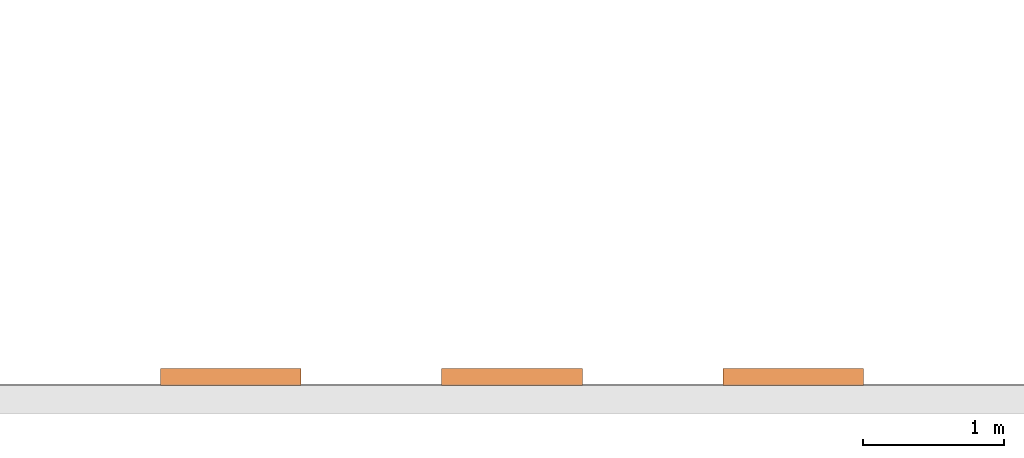
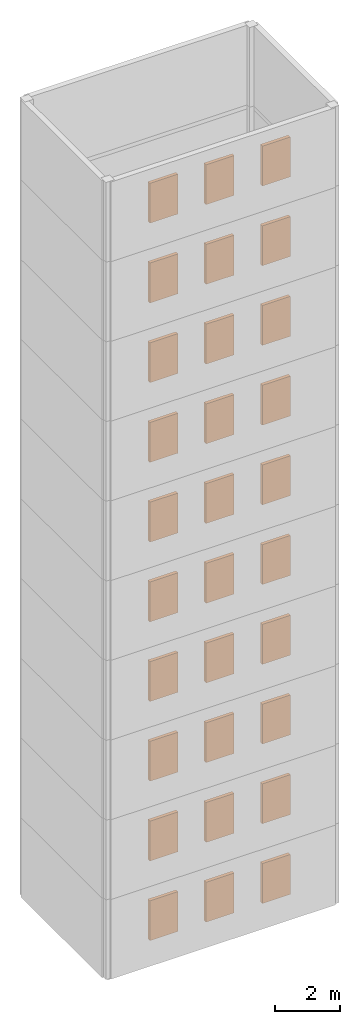
# Not in any storey, part 3 of 3: 30 proxies.
"""IFC4 model written with IfcOpenShell, lengths in metres."""

from ifc_helpers import new_model, si_unit, origin_with_axes, place, context, project, faceted_brep, element, save


model = new_model("IFC4")

# Units and contexts
model_context = context("Model", 3, precision=1e-05, world=origin_with_axes())
ifc_project = project(units=[si_unit("LENGTHUNIT", "METRE"), si_unit("AREAUNIT", "SQUARE_METRE"), si_unit("VOLUMEUNIT", "CUBIC_METRE")], contexts=[model_context])

# Proxies
proxy_1_placement = place(None, origin_with_axes())
element("IfcBuildingElementProxy", 1, at=proxy_1_placement, context=model_context, shape_type="SurfaceModel", body=[
    faceted_brep([(1.5, 0.0, 0.8), (1.5, 0.0, 2.3), (2.5, 0.0, 2.3), (2.5, 0.0, 0.8), (1.5, 0.12, 0.8), (2.5, 0.12, 0.8), (2.5, 0.12, 2.3), (1.5, 0.12, 2.3)], [[[0, 1, 2, 3]], [[4, 5, 6, 7]], [[0, 3, 5, 4]], [[1, 7, 6, 2]], [[0, 4, 7, 1]], [[3, 2, 6, 5]]]),
])
proxy_2_placement = place(None, origin_with_axes())
element("IfcBuildingElementProxy", 2, at=proxy_2_placement, context=model_context, shape_type="SurfaceModel", body=[
    faceted_brep([(3.5, 0.0, 0.8), (3.5, 0.0, 2.3), (4.5, 0.0, 2.3), (4.5, 0.0, 0.8), (3.5, 0.12, 0.8), (4.5, 0.12, 0.8), (4.5, 0.12, 2.3), (3.5, 0.12, 2.3)], [[[0, 1, 2, 3]], [[4, 5, 6, 7]], [[0, 3, 5, 4]], [[1, 7, 6, 2]], [[0, 4, 7, 1]], [[3, 2, 6, 5]]]),
])
proxy_3_placement = place(None, origin_with_axes())
element("IfcBuildingElementProxy", 3, at=proxy_3_placement, context=model_context, shape_type="SurfaceModel", body=[
    faceted_brep([(5.5, 0.0, 0.8), (5.5, 0.0, 2.3), (6.5, 0.0, 2.3), (6.5, 0.0, 0.8), (5.5, 0.12, 0.8), (6.5, 0.12, 0.8), (6.5, 0.12, 2.3), (5.5, 0.12, 2.3)], [[[0, 1, 2, 3]], [[4, 5, 6, 7]], [[0, 3, 5, 4]], [[1, 7, 6, 2]], [[0, 4, 7, 1]], [[3, 2, 6, 5]]]),
])
proxy_4_placement = place(None, origin_with_axes())
element("IfcBuildingElementProxy", 4, at=proxy_4_placement, context=model_context, shape_type="SurfaceModel", body=[
    faceted_brep([(1.5, 0.0, 3.8), (1.5, 0.0, 5.3), (2.5, 0.0, 5.3), (2.5, 0.0, 3.8), (1.5, 0.12, 3.8), (2.5, 0.12, 3.8), (2.5, 0.12, 5.3), (1.5, 0.12, 5.3)], [[[0, 1, 2, 3]], [[4, 5, 6, 7]], [[0, 3, 5, 4]], [[1, 7, 6, 2]], [[0, 4, 7, 1]], [[3, 2, 6, 5]]]),
])
proxy_5_placement = place(None, origin_with_axes())
element("IfcBuildingElementProxy", 5, at=proxy_5_placement, context=model_context, shape_type="SurfaceModel", body=[
    faceted_brep([(3.5, 0.0, 3.8), (3.5, 0.0, 5.3), (4.5, 0.0, 5.3), (4.5, 0.0, 3.8), (3.5, 0.12, 3.8), (4.5, 0.12, 3.8), (4.5, 0.12, 5.3), (3.5, 0.12, 5.3)], [[[0, 1, 2, 3]], [[4, 5, 6, 7]], [[0, 3, 5, 4]], [[1, 7, 6, 2]], [[0, 4, 7, 1]], [[3, 2, 6, 5]]]),
])
proxy_6_placement = place(None, origin_with_axes())
element("IfcBuildingElementProxy", 6, at=proxy_6_placement, context=model_context, shape_type="SurfaceModel", body=[
    faceted_brep([(5.5, 0.0, 3.8), (5.5, 0.0, 5.3), (6.5, 0.0, 5.3), (6.5, 0.0, 3.8), (5.5, 0.12, 3.8), (6.5, 0.12, 3.8), (6.5, 0.12, 5.3), (5.5, 0.12, 5.3)], [[[0, 1, 2, 3]], [[4, 5, 6, 7]], [[0, 3, 5, 4]], [[1, 7, 6, 2]], [[0, 4, 7, 1]], [[3, 2, 6, 5]]]),
])
proxy_7_placement = place(None, origin_with_axes())
element("IfcBuildingElementProxy", 7, at=proxy_7_placement, context=model_context, shape_type="SurfaceModel", body=[
    faceted_brep([(1.5, 0.0, 6.8), (1.5, 0.0, 8.3), (2.5, 0.0, 8.3), (2.5, 0.0, 6.8), (1.5, 0.12, 6.8), (2.5, 0.12, 6.8), (2.5, 0.12, 8.3), (1.5, 0.12, 8.3)], [[[0, 1, 2, 3]], [[4, 5, 6, 7]], [[0, 3, 5, 4]], [[1, 7, 6, 2]], [[0, 4, 7, 1]], [[3, 2, 6, 5]]]),
])
proxy_8_placement = place(None, origin_with_axes())
element("IfcBuildingElementProxy", 8, at=proxy_8_placement, context=model_context, shape_type="SurfaceModel", body=[
    faceted_brep([(3.5, 0.0, 6.8), (3.5, 0.0, 8.3), (4.5, 0.0, 8.3), (4.5, 0.0, 6.8), (3.5, 0.12, 6.8), (4.5, 0.12, 6.8), (4.5, 0.12, 8.3), (3.5, 0.12, 8.3)], [[[0, 1, 2, 3]], [[4, 5, 6, 7]], [[0, 3, 5, 4]], [[1, 7, 6, 2]], [[0, 4, 7, 1]], [[3, 2, 6, 5]]]),
])
proxy_9_placement = place(None, origin_with_axes())
element("IfcBuildingElementProxy", 9, at=proxy_9_placement, context=model_context, shape_type="SurfaceModel", body=[
    faceted_brep([(5.5, 0.0, 6.8), (5.5, 0.0, 8.3), (6.5, 0.0, 8.3), (6.5, 0.0, 6.8), (5.5, 0.12, 6.8), (6.5, 0.12, 6.8), (6.5, 0.12, 8.3), (5.5, 0.12, 8.3)], [[[0, 1, 2, 3]], [[4, 5, 6, 7]], [[0, 3, 5, 4]], [[1, 7, 6, 2]], [[0, 4, 7, 1]], [[3, 2, 6, 5]]]),
])
proxy_10_placement = place(None, origin_with_axes())
element("IfcBuildingElementProxy", 10, at=proxy_10_placement, context=model_context, shape_type="SurfaceModel", body=[
    faceted_brep([(1.5, 0.0, 9.8), (1.5, 0.0, 11.3), (2.5, 0.0, 11.3), (2.5, 0.0, 9.8), (1.5, 0.12, 9.8), (2.5, 0.12, 9.8), (2.5, 0.12, 11.3), (1.5, 0.12, 11.3)], [[[0, 1, 2, 3]], [[4, 5, 6, 7]], [[0, 3, 5, 4]], [[1, 7, 6, 2]], [[0, 4, 7, 1]], [[3, 2, 6, 5]]]),
])
proxy_11_placement = place(None, origin_with_axes())
element("IfcBuildingElementProxy", 11, at=proxy_11_placement, context=model_context, shape_type="SurfaceModel", body=[
    faceted_brep([(3.5, 0.0, 9.8), (3.5, 0.0, 11.3), (4.5, 0.0, 11.3), (4.5, 0.0, 9.8), (3.5, 0.12, 9.8), (4.5, 0.12, 9.8), (4.5, 0.12, 11.3), (3.5, 0.12, 11.3)], [[[0, 1, 2, 3]], [[4, 5, 6, 7]], [[0, 3, 5, 4]], [[1, 7, 6, 2]], [[0, 4, 7, 1]], [[3, 2, 6, 5]]]),
])
proxy_12_placement = place(None, origin_with_axes())
element("IfcBuildingElementProxy", 12, at=proxy_12_placement, context=model_context, shape_type="SurfaceModel", body=[
    faceted_brep([(5.5, 0.0, 9.8), (5.5, 0.0, 11.3), (6.5, 0.0, 11.3), (6.5, 0.0, 9.8), (5.5, 0.12, 9.8), (6.5, 0.12, 9.8), (6.5, 0.12, 11.3), (5.5, 0.12, 11.3)], [[[0, 1, 2, 3]], [[4, 5, 6, 7]], [[0, 3, 5, 4]], [[1, 7, 6, 2]], [[0, 4, 7, 1]], [[3, 2, 6, 5]]]),
])
proxy_13_placement = place(None, origin_with_axes())
element("IfcBuildingElementProxy", 13, at=proxy_13_placement, context=model_context, shape_type="SurfaceModel", body=[
    faceted_brep([(1.5, 0.0, 12.8), (1.5, 0.0, 14.3), (2.5, 0.0, 14.3), (2.5, 0.0, 12.8), (1.5, 0.12, 12.8), (2.5, 0.12, 12.8), (2.5, 0.12, 14.3), (1.5, 0.12, 14.3)], [[[0, 1, 2, 3]], [[4, 5, 6, 7]], [[0, 3, 5, 4]], [[1, 7, 6, 2]], [[0, 4, 7, 1]], [[3, 2, 6, 5]]]),
])
proxy_14_placement = place(None, origin_with_axes())
element("IfcBuildingElementProxy", 14, at=proxy_14_placement, context=model_context, shape_type="SurfaceModel", body=[
    faceted_brep([(3.5, 0.0, 12.8), (3.5, 0.0, 14.3), (4.5, 0.0, 14.3), (4.5, 0.0, 12.8), (3.5, 0.12, 12.8), (4.5, 0.12, 12.8), (4.5, 0.12, 14.3), (3.5, 0.12, 14.3)], [[[0, 1, 2, 3]], [[4, 5, 6, 7]], [[0, 3, 5, 4]], [[1, 7, 6, 2]], [[0, 4, 7, 1]], [[3, 2, 6, 5]]]),
])
proxy_15_placement = place(None, origin_with_axes())
element("IfcBuildingElementProxy", 15, at=proxy_15_placement, context=model_context, shape_type="SurfaceModel", body=[
    faceted_brep([(5.5, 0.0, 12.8), (5.5, 0.0, 14.3), (6.5, 0.0, 14.3), (6.5, 0.0, 12.8), (5.5, 0.12, 12.8), (6.5, 0.12, 12.8), (6.5, 0.12, 14.3), (5.5, 0.12, 14.3)], [[[0, 1, 2, 3]], [[4, 5, 6, 7]], [[0, 3, 5, 4]], [[1, 7, 6, 2]], [[0, 4, 7, 1]], [[3, 2, 6, 5]]]),
])
proxy_16_placement = place(None, origin_with_axes())
element("IfcBuildingElementProxy", 16, at=proxy_16_placement, context=model_context, shape_type="SurfaceModel", body=[
    faceted_brep([(1.5, 0.0, 15.8), (1.5, 0.0, 17.3), (2.5, 0.0, 17.3), (2.5, 0.0, 15.8), (1.5, 0.12, 15.8), (2.5, 0.12, 15.8), (2.5, 0.12, 17.3), (1.5, 0.12, 17.3)], [[[0, 1, 2, 3]], [[4, 5, 6, 7]], [[0, 3, 5, 4]], [[1, 7, 6, 2]], [[0, 4, 7, 1]], [[3, 2, 6, 5]]]),
])
proxy_17_placement = place(None, origin_with_axes())
element("IfcBuildingElementProxy", 17, at=proxy_17_placement, context=model_context, shape_type="SurfaceModel", body=[
    faceted_brep([(3.5, 0.0, 15.8), (3.5, 0.0, 17.3), (4.5, 0.0, 17.3), (4.5, 0.0, 15.8), (3.5, 0.12, 15.8), (4.5, 0.12, 15.8), (4.5, 0.12, 17.3), (3.5, 0.12, 17.3)], [[[0, 1, 2, 3]], [[4, 5, 6, 7]], [[0, 3, 5, 4]], [[1, 7, 6, 2]], [[0, 4, 7, 1]], [[3, 2, 6, 5]]]),
])
proxy_18_placement = place(None, origin_with_axes())
element("IfcBuildingElementProxy", 18, at=proxy_18_placement, context=model_context, shape_type="SurfaceModel", body=[
    faceted_brep([(5.5, 0.0, 15.8), (5.5, 0.0, 17.3), (6.5, 0.0, 17.3), (6.5, 0.0, 15.8), (5.5, 0.12, 15.8), (6.5, 0.12, 15.8), (6.5, 0.12, 17.3), (5.5, 0.12, 17.3)], [[[0, 1, 2, 3]], [[4, 5, 6, 7]], [[0, 3, 5, 4]], [[1, 7, 6, 2]], [[0, 4, 7, 1]], [[3, 2, 6, 5]]]),
])
proxy_19_placement = place(None, origin_with_axes())
element("IfcBuildingElementProxy", 19, at=proxy_19_placement, context=model_context, shape_type="SurfaceModel", body=[
    faceted_brep([(1.5, 0.0, 18.8), (1.5, 0.0, 20.3), (2.5, 0.0, 20.3), (2.5, 0.0, 18.8), (1.5, 0.12, 18.8), (2.5, 0.12, 18.8), (2.5, 0.12, 20.3), (1.5, 0.12, 20.3)], [[[0, 1, 2, 3]], [[4, 5, 6, 7]], [[0, 3, 5, 4]], [[1, 7, 6, 2]], [[0, 4, 7, 1]], [[3, 2, 6, 5]]]),
])
proxy_20_placement = place(None, origin_with_axes())
element("IfcBuildingElementProxy", 20, at=proxy_20_placement, context=model_context, shape_type="SurfaceModel", body=[
    faceted_brep([(3.5, 0.0, 18.8), (3.5, 0.0, 20.3), (4.5, 0.0, 20.3), (4.5, 0.0, 18.8), (3.5, 0.12, 18.8), (4.5, 0.12, 18.8), (4.5, 0.12, 20.3), (3.5, 0.12, 20.3)], [[[0, 1, 2, 3]], [[4, 5, 6, 7]], [[0, 3, 5, 4]], [[1, 7, 6, 2]], [[0, 4, 7, 1]], [[3, 2, 6, 5]]]),
])
proxy_21_placement = place(None, origin_with_axes())
element("IfcBuildingElementProxy", 21, at=proxy_21_placement, context=model_context, shape_type="SurfaceModel", body=[
    faceted_brep([(5.5, 0.0, 18.8), (5.5, 0.0, 20.3), (6.5, 0.0, 20.3), (6.5, 0.0, 18.8), (5.5, 0.12, 18.8), (6.5, 0.12, 18.8), (6.5, 0.12, 20.3), (5.5, 0.12, 20.3)], [[[0, 1, 2, 3]], [[4, 5, 6, 7]], [[0, 3, 5, 4]], [[1, 7, 6, 2]], [[0, 4, 7, 1]], [[3, 2, 6, 5]]]),
])
proxy_22_placement = place(None, origin_with_axes())
element("IfcBuildingElementProxy", 22, at=proxy_22_placement, context=model_context, shape_type="SurfaceModel", body=[
    faceted_brep([(1.5, 0.0, 21.8), (1.5, 0.0, 23.3), (2.5, 0.0, 23.3), (2.5, 0.0, 21.8), (1.5, 0.12, 21.8), (2.5, 0.12, 21.8), (2.5, 0.12, 23.3), (1.5, 0.12, 23.3)], [[[0, 1, 2, 3]], [[4, 5, 6, 7]], [[0, 3, 5, 4]], [[1, 7, 6, 2]], [[0, 4, 7, 1]], [[3, 2, 6, 5]]]),
])
proxy_23_placement = place(None, origin_with_axes())
element("IfcBuildingElementProxy", 23, at=proxy_23_placement, context=model_context, shape_type="SurfaceModel", body=[
    faceted_brep([(3.5, 0.0, 21.8), (3.5, 0.0, 23.3), (4.5, 0.0, 23.3), (4.5, 0.0, 21.8), (3.5, 0.12, 21.8), (4.5, 0.12, 21.8), (4.5, 0.12, 23.3), (3.5, 0.12, 23.3)], [[[0, 1, 2, 3]], [[4, 5, 6, 7]], [[0, 3, 5, 4]], [[1, 7, 6, 2]], [[0, 4, 7, 1]], [[3, 2, 6, 5]]]),
])
proxy_24_placement = place(None, origin_with_axes())
element("IfcBuildingElementProxy", 24, at=proxy_24_placement, context=model_context, shape_type="SurfaceModel", body=[
    faceted_brep([(5.5, 0.0, 21.8), (5.5, 0.0, 23.3), (6.5, 0.0, 23.3), (6.5, 0.0, 21.8), (5.5, 0.12, 21.8), (6.5, 0.12, 21.8), (6.5, 0.12, 23.3), (5.5, 0.12, 23.3)], [[[0, 1, 2, 3]], [[4, 5, 6, 7]], [[0, 3, 5, 4]], [[1, 7, 6, 2]], [[0, 4, 7, 1]], [[3, 2, 6, 5]]]),
])
proxy_25_placement = place(None, origin_with_axes())
element("IfcBuildingElementProxy", 25, at=proxy_25_placement, context=model_context, shape_type="SurfaceModel", body=[
    faceted_brep([(1.5, 0.0, 24.8), (1.5, 0.0, 26.3), (2.5, 0.0, 26.3), (2.5, 0.0, 24.8), (1.5, 0.12, 24.8), (2.5, 0.12, 24.8), (2.5, 0.12, 26.3), (1.5, 0.12, 26.3)], [[[0, 1, 2, 3]], [[4, 5, 6, 7]], [[0, 3, 5, 4]], [[1, 7, 6, 2]], [[0, 4, 7, 1]], [[3, 2, 6, 5]]]),
])
proxy_26_placement = place(None, origin_with_axes())
element("IfcBuildingElementProxy", 26, at=proxy_26_placement, context=model_context, shape_type="SurfaceModel", body=[
    faceted_brep([(3.5, 0.0, 24.8), (3.5, 0.0, 26.3), (4.5, 0.0, 26.3), (4.5, 0.0, 24.8), (3.5, 0.12, 24.8), (4.5, 0.12, 24.8), (4.5, 0.12, 26.3), (3.5, 0.12, 26.3)], [[[0, 1, 2, 3]], [[4, 5, 6, 7]], [[0, 3, 5, 4]], [[1, 7, 6, 2]], [[0, 4, 7, 1]], [[3, 2, 6, 5]]]),
])
proxy_27_placement = place(None, origin_with_axes())
element("IfcBuildingElementProxy", 27, at=proxy_27_placement, context=model_context, shape_type="SurfaceModel", body=[
    faceted_brep([(5.5, 0.0, 24.8), (5.5, 0.0, 26.3), (6.5, 0.0, 26.3), (6.5, 0.0, 24.8), (5.5, 0.12, 24.8), (6.5, 0.12, 24.8), (6.5, 0.12, 26.3), (5.5, 0.12, 26.3)], [[[0, 1, 2, 3]], [[4, 5, 6, 7]], [[0, 3, 5, 4]], [[1, 7, 6, 2]], [[0, 4, 7, 1]], [[3, 2, 6, 5]]]),
])
proxy_28_placement = place(None, origin_with_axes())
element("IfcBuildingElementProxy", 28, at=proxy_28_placement, context=model_context, shape_type="SurfaceModel", body=[
    faceted_brep([(1.5, 0.0, 27.8), (1.5, 0.0, 29.3), (2.5, 0.0, 29.3), (2.5, 0.0, 27.8), (1.5, 0.12, 27.8), (2.5, 0.12, 27.8), (2.5, 0.12, 29.3), (1.5, 0.12, 29.3)], [[[0, 1, 2, 3]], [[4, 5, 6, 7]], [[0, 3, 5, 4]], [[1, 7, 6, 2]], [[0, 4, 7, 1]], [[3, 2, 6, 5]]]),
])
proxy_29_placement = place(None, origin_with_axes())
element("IfcBuildingElementProxy", 29, at=proxy_29_placement, context=model_context, shape_type="SurfaceModel", body=[
    faceted_brep([(3.5, 0.0, 27.8), (3.5, 0.0, 29.3), (4.5, 0.0, 29.3), (4.5, 0.0, 27.8), (3.5, 0.12, 27.8), (4.5, 0.12, 27.8), (4.5, 0.12, 29.3), (3.5, 0.12, 29.3)], [[[0, 1, 2, 3]], [[4, 5, 6, 7]], [[0, 3, 5, 4]], [[1, 7, 6, 2]], [[0, 4, 7, 1]], [[3, 2, 6, 5]]]),
])
proxy_30_placement = place(None, origin_with_axes())
element("IfcBuildingElementProxy", 30, at=proxy_30_placement, context=model_context, shape_type="SurfaceModel", body=[
    faceted_brep([(5.5, 0.0, 27.8), (5.5, 0.0, 29.3), (6.5, 0.0, 29.3), (6.5, 0.0, 27.8), (5.5, 0.12, 27.8), (6.5, 0.12, 27.8), (6.5, 0.12, 29.3), (5.5, 0.12, 29.3)], [[[0, 1, 2, 3]], [[4, 5, 6, 7]], [[0, 3, 5, 4]], [[1, 7, 6, 2]], [[0, 4, 7, 1]], [[3, 2, 6, 5]]]),
])

save(model, "model.ifc")
